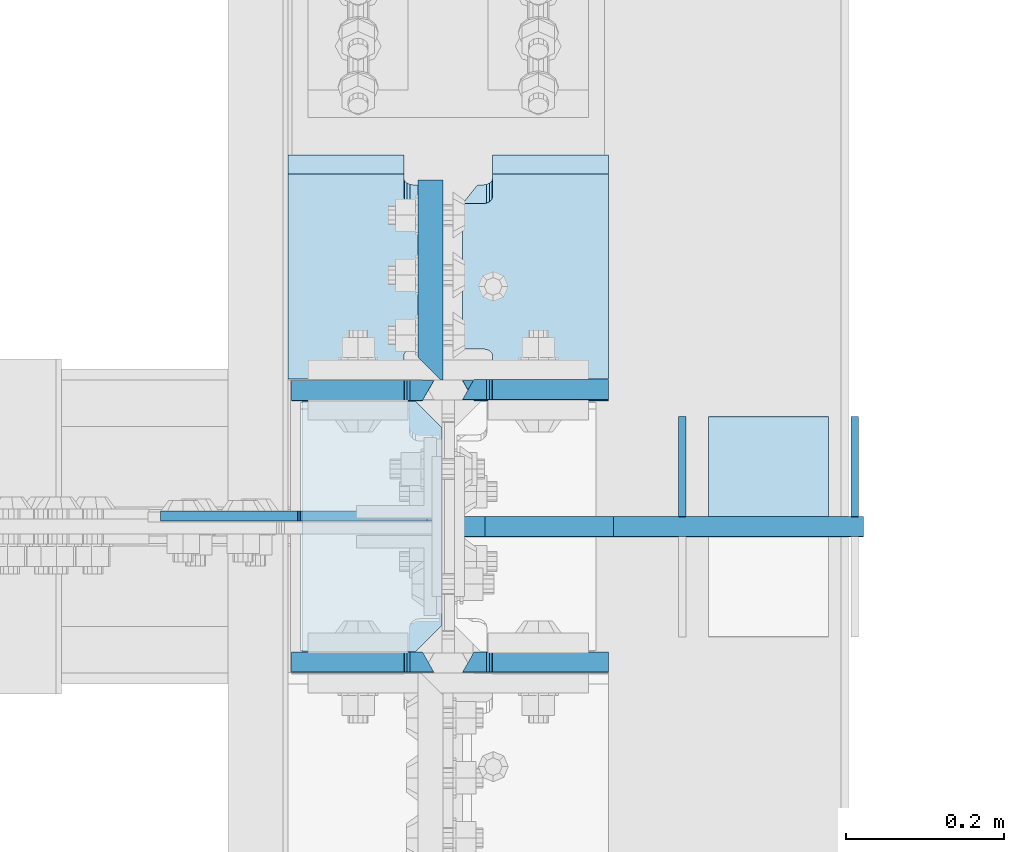
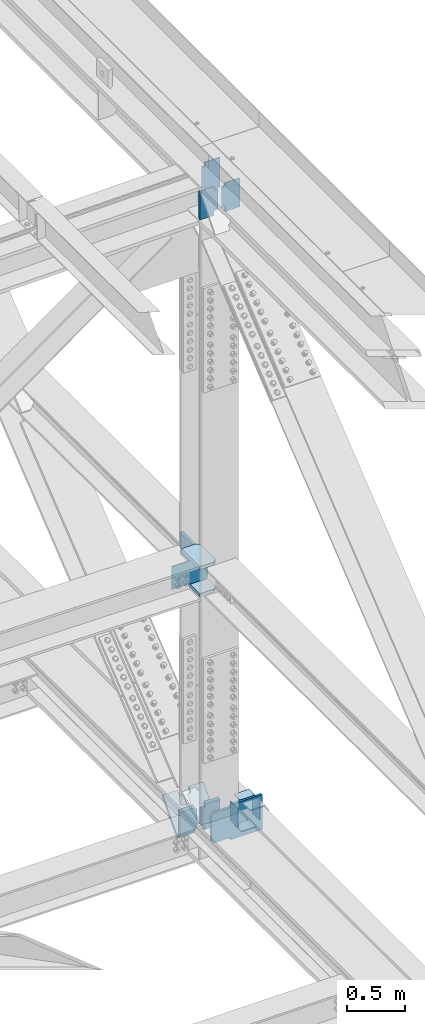
# One storey, part 3621 of 3843: 16 plates, 7 elements without a shape of their own.
"""IFC2X3 building model written with IfcOpenShell, lengths in millimetres."""

from ifc_helpers import new_model, si_unit, frame, origin_with_axes, place, context, subcontext, project, spatial, faceted_brep, material, type_object, element, aggregate, save


model = new_model("IFC2X3")

# Units and contexts
model_context = context("Model", 3, precision=1e-05, world=origin_with_axes())
body_context = subcontext(model_context, "Body", "Model", "MODEL_VIEW")
ifc_project = project(units=[si_unit("LENGTHUNIT", "METRE", prefix="MILLI"), si_unit("AREAUNIT", "SQUARE_METRE"), si_unit("VOLUMEUNIT", "CUBIC_METRE"), si_unit("MASSUNIT", "GRAM", prefix="KILO"), si_unit("TIMEUNIT", "SECOND"), si_unit("PLANEANGLEUNIT", "RADIAN"), si_unit("SOLIDANGLEUNIT", "STERADIAN"), si_unit("THERMODYNAMICTEMPERATUREUNIT", "DEGREE_CELSIUS"), si_unit("LUMINOUSINTENSITYUNIT", "LUMEN")], contexts=[model_context])

# Site, building, storey
site_placement = place(None, origin_with_axes())
site = spatial("IfcSite", under=ifc_project, at=site_placement, CompositionType="ELEMENT")
building_placement = place(site_placement, origin_with_axes())
building = spatial("IfcBuilding", under=site, at=building_placement, Name="Undefined", CompositionType="ELEMENT")
storey_placement = place(building_placement, origin_with_axes())
storey = spatial("IfcBuildingStorey", under=building, at=storey_placement, Name="Undefined", CompositionType="ELEMENT", Elevation=0.0)

# Assembly, plate
assembly_1_placement = place(storey_placement, origin_with_axes())
assembly_1 = element("IfcElementAssembly", 1, at=assembly_1_placement, inside=storey, Name="BEAM", AssemblyPlace="NOTDEFINED", PredefinedType="RIGID_FRAME")
ifc_material = material(Name="STEEL/A572-50")
plate_type_1 = type_object("IfcPlateType", PredefinedType="NOTDEFINED")
plate_1_placement = place(assembly_1_placement, frame((85852.0, 75800.2611777543, 39371.5363592028), z_axis=(0.0, 0.00349392500078829, 0.999993896225416), x_axis=(-1.0, 0.0, 0.0)))
plate_1 = element("IfcPlate", 2, at=plate_1_placement, type_object=plate_type_1, material=ifc_material, Name="PLATE", context=body_context, shape_type="Brep", body=[
    faceted_brep([(146.843749999985, -12.7000000009139, 314.307995056697), (146.843749999985, 12.6999999991967, 299.816503301714), (0.0, 12.6999999991967, 299.816503301721), (0.0, -12.7000000009139, 314.307995056697), (0.0, -12.700000000099, 19.4053954921328), (0.0, 12.6999999999243, 33.8968872505939), (146.843749999985, 12.6999999999243, 33.8968872505939), (146.843749999985, -12.700000000099, 19.4053954921328), (146.843749999985, 12.6999999998661, 56.9952036572431), (146.843749999985, -12.7000000002008, 56.9064567435853), (147.810479922569, 12.6999999998661, 61.855312840773), (147.810479922569, -12.7000000002154, 61.7665659271224), (150.563493823051, 12.699999999837, 65.9755144581213), (150.563493823051, -12.7000000002299, 65.8867675444562), (154.683670291211, 12.6999999998516, 68.728545162754), (154.683670291211, -12.7000000002445, 68.6397982490817), (159.543749809251, 12.699999999837, 69.6952809861614), (159.543749809251, -12.700000000259, 69.6065340725108), (170.452258243124, 12.699999999837, 69.6952809861614), (184.943749999991, -12.700000000259, 69.6065340725108), (184.943749999991, -12.6999999997643, 263.417469235843), (170.452258242993, 12.7000000003609, 263.506216142385), (159.543749809251, 12.6999999992186, 263.506216155103), (159.543749809251, -12.7000000008484, 263.417469232591), (154.683670291211, 12.6999999992113, 264.472951978518), (154.683670291211, -12.7000000008557, 264.384205056005), (150.563493823051, 12.699999999204, 267.225982683158), (150.563493823051, -12.7000000008629, 267.137235760645), (147.810479922569, 12.6999999991895, 271.346184300499), (147.810479922569, -12.7000000008702, 271.257437377986), (146.843749999985, 12.6999999991749, 276.206293484036), (146.843749999985, -12.7000000008848, 276.117546561523)], [[[0, 1, 2, 3]], [[4, 5, 6, 7]], [[7, 6, 8, 9]], [[9, 8, 10, 11]], [[11, 10, 12, 13]], [[13, 12, 14, 15]], [[15, 14, 16, 17]], [[17, 16, 18, 19]], [[20, 19, 18, 21]], [[22, 23, 20, 21]], [[23, 22, 24, 25]], [[25, 24, 26, 27]], [[27, 26, 28, 29]], [[29, 28, 30, 31]], [[4, 7, 9, 11, 13, 15, 17, 19, 20, 23, 25, 27, 29, 31, 0, 3]], [[5, 4, 3, 2]], [[30, 28, 26, 24, 22, 21, 18, 16, 14, 12, 10, 8, 6, 5, 2, 1]], [[31, 30, 1, 0]]]),
])

# Assembly, plates
assembly_2_placement = place(storey_placement, origin_with_axes())
assembly_2 = element("IfcElementAssembly", 3, at=assembly_2_placement, inside=storey, Name="BEAM", AssemblyPlace="NOTDEFINED", PredefinedType="RIGID_FRAME")
plate_2_placement = place(assembly_2_placement, frame((85852.0, 75455.6307364582, 46144.796667349), z_axis=(0.0, 0.00329764299921226, 0.999994562760543), x_axis=(-1.0, 0.0, 0.0)))
plate_2 = element("IfcPlate", 4, at=plate_2_placement, type_object=plate_type_1, material=ifc_material, Name="PLATE", context=body_context, shape_type="Brep", body=[
    faceted_brep([(146.84375, -12.7000000000553, 38.0114858507077), (146.84375, 12.7000000001281, 38.1002327741662), (147.810479922584, 12.7000000001281, 42.9603419576888), (147.810479922584, -12.7000000000553, 42.8715950342303), (150.563493823065, 12.7000000001281, 47.0805435750153), (150.563493823065, -12.7000000000553, 46.9917966515568), (154.683670291226, 12.7000000001281, 49.8335742796335), (154.683670291226, -12.7000000000407, 49.7448273561822), (159.543749809265, 12.7000000001426, 50.8003101030481), (159.543749809265, -12.7000000000407, 50.7115631795969), (184.943749999991, 12.7000000001426, 50.8003101030481), (170.452258242891, -12.7000000000407, 50.7115631795969), (184.943749999991, 12.7000000002081, 263.506216153903), (170.452258242891, -12.699999999837, 263.417469255888), (159.543749809251, 12.6999999992186, 263.506216155103), (159.543749809251, -12.7000000008484, 263.417469232591), (154.683670291211, 12.6999999992113, 264.472951978518), (154.683670291211, -12.7000000008557, 264.384205056005), (150.563493823051, 12.699999999204, 267.225982683158), (150.563493823051, -12.7000000008629, 267.137235760645), (147.810479922569, 12.6999999991895, 271.346184300499), (147.810479922569, -12.7000000008702, 271.257437377986), (146.843749999985, 12.6999999991749, 276.206293484036), (146.843749999985, -12.7000000008848, 276.117546561523), (146.843749999985, 12.700000001656, 303.95027208051), (146.843749999985, -12.6999999984982, 289.458780324741), (0.0, 12.700000001656, 303.95027208051), (0.0, -12.6999999984982, 289.458780324741), (0.0, 12.6999999999971, 0.0), (0.0, -12.7000000000771, 14.4914917543283), (146.843749999985, -12.7000000000771, 14.4914917543283), (146.843749999985, 12.7000000000262, 4.36557456851006e-11)], [[[0, 1, 2, 3]], [[3, 2, 4, 5]], [[5, 4, 6, 7]], [[7, 6, 8, 9]], [[9, 8, 10, 11]], [[12, 13, 11, 10]], [[14, 15, 13, 12]], [[15, 14, 16, 17]], [[17, 16, 18, 19]], [[19, 18, 20, 21]], [[21, 20, 22, 23]], [[24, 25, 23, 22]], [[26, 27, 25, 24]], [[27, 26, 28, 29]], [[0, 3, 5, 7, 9, 11, 13, 15, 17, 19, 21, 23, 25, 27, 29, 30]], [[1, 0, 30, 31]], [[26, 24, 22, 20, 18, 16, 14, 12, 10, 8, 6, 4, 2, 1, 31, 28]], [[30, 29, 28, 31]]]),
])
plate_3_placement = place(assembly_2_placement, frame((85852.0, 75801.7043463839, 46143.8045161096), z_axis=(0.0, 0.00329764299921226, 0.999994562760543), x_axis=(-1.0, 0.0, 0.0)))
plate_3 = element("IfcPlate", 5, at=plate_3_placement, type_object=plate_type_1, material=ifc_material, Name="PLATE", context=body_context, shape_type="Brep", body=[
    faceted_brep([(146.843749999985, 12.7000000017288, 314.312938163443), (0.0, 12.7000000017288, 314.312938163443), (0.0, -12.69999999844, 299.821446403119), (146.843749999985, -12.69999999844, 299.821446403119), (146.843749999985, -12.7000000000771, 14.4914917543283), (0.0, -12.7000000000771, 14.4914917543283), (0.0, 12.6999999999971, 0.0), (146.843749999985, 12.7000000000262, 4.36557456851006e-11), (146.843749999985, 12.6999999999098, 38.1890602041385), (146.843749999985, -12.7000000001572, 38.1003132816259), (147.810479922569, 12.6999999998952, 43.0491693876829), (147.810479922569, -12.7000000001644, 42.9604224651703), (150.563493823051, 12.6999999998734, 47.169371005024), (150.563493823051, -12.7000000001863, 47.0806240825113), (154.683670291211, 12.6999999998734, 49.9224017096567), (154.683670291211, -12.7000000001935, 49.833654787144), (159.543749809251, 12.6999999998661, 50.8891375330786), (159.543749809251, -12.7000000001935, 50.800390610566), (184.943749999991, 12.7000000001572, 50.8891375333405), (170.452258242833, -12.7000000000262, 50.800390609882), (184.943749999991, 12.7000000002081, 263.506216153903), (170.452258242891, -12.699999999837, 263.417469255888), (159.543749809251, 12.6999999992186, 263.506216155103), (159.543749809251, -12.7000000008484, 263.417469232591), (154.683670291211, 12.6999999992113, 264.472951978518), (154.683670291211, -12.7000000008557, 264.384205056005), (150.563493823051, 12.699999999204, 267.225982683158), (150.563493823051, -12.7000000008629, 267.137235760645), (147.810479922569, 12.6999999991895, 271.346184300499), (147.810479922569, -12.7000000008702, 271.257437377986), (146.843749999985, 12.6999999991749, 276.206293484036), (146.843749999985, -12.7000000008848, 276.117546561523)], [[[0, 1, 2, 3]], [[4, 5, 6, 7]], [[8, 9, 4, 7]], [[9, 8, 10, 11]], [[11, 10, 12, 13]], [[13, 12, 14, 15]], [[15, 14, 16, 17]], [[17, 16, 18, 19]], [[20, 21, 19, 18]], [[22, 23, 21, 20]], [[23, 22, 24, 25]], [[25, 24, 26, 27]], [[27, 26, 28, 29]], [[29, 28, 30, 31]], [[31, 30, 0, 3]], [[5, 4, 9, 11, 13, 15, 17, 19, 21, 23, 25, 27, 29, 31, 3, 2]], [[6, 5, 2, 1]], [[30, 28, 26, 24, 22, 20, 18, 16, 14, 12, 10, 8, 7, 6, 1, 0]]]),
])

# Assembly, plate
assembly_3_placement = place(storey_placement, origin_with_axes())
assembly_3 = element("IfcElementAssembly", 6, at=assembly_3_placement, inside=storey, Name="COLUMN", AssemblyPlace="NOTDEFINED", PredefinedType="RIGID_FRAME")
plate_type_2 = type_object("IfcPlateType", PredefinedType="NOTDEFINED")
plate_4_placement = place(assembly_3_placement, frame((85640.8625, 75641.9937500954, 42192.071348413), z_axis=(-0.707106781186548, 0.0, 0.707106781186548), x_axis=(-0.707106781186548, 0.0, -0.707106781186548)))
plate_4 = element("IfcPlate", 7, at=plate_4_placement, type_object=plate_type_2, material=ifc_material, Name="PLATE", context=body_context, shape_type="Brep", body=[
    faceted_brep([(0.0, -6.3499999046162, 0.0), (-152.665587827403, -6.34999999999854, 152.665587827403), (-152.665587827403, 6.34999999999854, 152.665587827403), (7.27595761418343e-12, 6.3499999046162, 0.0), (-152.665587827112, -6.34999999999854, 179.606356190761), (-152.665587827112, 6.34999999999854, 179.606356190761), (-39.2898544208874, -6.34999999999854, 292.982089845096), (-39.2898544208874, 6.34999999999854, 292.982089845096), (-37.2519695532828, -6.34999999999854, 291.620418710037), (-37.2519695532828, 6.34999999999854, 291.620418710037), (-34.8481204507552, -6.34999999999854, 291.142263394238), (-34.8481204507552, 6.34999999999854, 291.142263394238), (-32.4442713482422, -6.34999999999854, 291.620418710056), (-32.4442713482422, 6.34999999999854, 291.620418710056), (-30.406386480623, -6.34999999999854, 292.98208984514), (-30.406386480623, 6.34999999999854, 292.98208984514), (90.8754652461794, -6.34999999999854, 414.263941571935), (90.8754652461794, 6.34999999999854, 414.263941571935), (261.500331545671, -6.34999999999854, 243.639075272451), (261.500331545671, 6.34999999999854, 243.639075272451), (140.316501924579, -6.34999999999854, 122.455245651345), (140.316501924579, 6.34999999999854, 122.455245651345), (138.924780842135, -6.34999999999854, 120.372387859356), (138.924780842135, 6.34999999999854, 120.372387859356), (138.436073388089, -6.34999999999854, 117.915489575513), (138.436073388089, 6.34999999999854, 117.915489575513), (138.924780842121, -6.34999999999854, 115.458591291659), (138.924780842121, 6.34999999999854, 115.458591291659), (140.316501893642, -6.34999999999854, 113.375733530571), (140.316501893642, 6.34999999999854, 113.375733530571), (26.9407683632217, -6.34999999999854, 1.30967237055302e-10), (26.9407683632217, 6.34999999999854, 1.30967237055302e-10)], [[[0, 1, 2, 3]], [[1, 4, 5, 2]], [[4, 6, 7, 5]], [[6, 8, 9, 7]], [[8, 10, 11, 9]], [[10, 12, 13, 11]], [[12, 14, 15, 13]], [[14, 16, 17, 15]], [[16, 18, 19, 17]], [[18, 20, 21, 19]], [[20, 22, 23, 21]], [[22, 24, 25, 23]], [[24, 26, 27, 25]], [[26, 28, 29, 27]], [[28, 30, 31, 29]], [[30, 0, 3, 31]], [[5, 7, 9, 11, 13, 15, 17, 19, 21, 23, 25, 27, 29, 31, 3, 2]], [[30, 28, 26, 24, 22, 20, 18, 16, 14, 12, 10, 8, 6, 4, 1, 0]]]),
])

# Plate
plate_type_3 = type_object("IfcPlateType", PredefinedType="NOTDEFINED")
plate_5_placement = place(assembly_1_placement, frame((85630.54375, 75800.2611777543, 39371.5363592028), z_axis=(0.0, 0.00349392500078829, 0.999993896225416), x_axis=(-1.0, 0.0, 0.0)))
plate_5 = element("IfcPlate", 8, at=plate_5_placement, type_object=plate_type_3, material=ifc_material, Name="PLATE", context=body_context, shape_type="Brep", body=[
    faceted_brep([(180.974999999991, -12.7000000009139, 314.307995056697), (180.974999999991, 12.6999999991967, 299.816503301721), (38.1000000000058, 12.6999999991967, 299.816503301714), (38.1000000000058, -12.6996899253718, 314.217780397244), (38.1000000000058, -12.7000000008848, 276.117546561538), (38.1000000000058, 12.6999999991749, 276.206293484051), (37.1332700774219, 12.6999999991895, 271.346184300513), (37.1332700774219, -12.7000000008702, 271.257437378001), (34.3802561769407, 12.699999999204, 267.225982683172), (34.3802561769407, -12.7000000008629, 267.13723576066), (30.2600797087798, 12.6999999992113, 264.472951978532), (30.2600797087798, -12.7000000008557, 264.38420505602), (25.4000001907407, 12.6999999992186, 263.506216155118), (25.4000001907407, -12.7000000008484, 263.417469232605), (14.4914917569986, 12.7000000003463, 263.506216154878), (0.0, -12.6999999997643, 263.417469223023), (14.4914917568676, 12.699999999837, 69.695280986205), (0.0, -12.700000000259, 69.6065340725545), (25.4000001907407, 12.699999999837, 69.695280986205), (25.4000001907407, -12.700000000259, 69.6065340725545), (30.2600797087798, 12.6999999998516, 68.7285451627977), (30.2600797087798, -12.7000000002445, 68.6397982491253), (34.3802561769407, 12.699999999837, 65.975514458165), (34.3802561769407, -12.7000000002299, 65.8867675445072), (37.1332700774219, 12.6999999998661, 61.8553128408166), (37.1332700774219, -12.7000000002154, 61.7665659271661), (38.1000000000058, 12.6999999998661, 56.9952036572868), (38.1000000000058, -12.7000000002008, 56.906456743629), (38.1000000000058, 12.6999999999243, 33.8968872505793), (38.1000000000058, -12.700000000099, 19.4053954921183), (180.974999999991, 12.6999999999243, 33.8968872505793), (180.974999999991, -12.700000000099, 19.4053954921183)], [[[0, 1, 2, 3]], [[4, 5, 6, 7]], [[7, 6, 8, 9]], [[9, 8, 10, 11]], [[11, 10, 12, 13]], [[13, 12, 14, 15]], [[14, 16, 17, 15]], [[18, 19, 17, 16]], [[19, 18, 20, 21]], [[21, 20, 22, 23]], [[23, 22, 24, 25]], [[25, 24, 26, 27]], [[27, 26, 28, 29]], [[30, 31, 29, 28]], [[4, 7, 9, 11, 13, 15, 17, 19, 21, 23, 25, 27, 29, 31, 0, 3]], [[5, 4, 3, 2]], [[30, 28, 26, 24, 22, 20, 18, 16, 14, 12, 10, 8, 6, 5, 2, 1]], [[31, 30, 1, 0]]]),
])

plate_6_placement = place(assembly_2_placement, frame((85630.54375, 75455.6307364582, 46144.796667349), z_axis=(0.0, 0.00329764299921226, 0.999994562760543), x_axis=(-1.0, 0.0, 0.0)))
plate_6 = element("IfcPlate", 9, at=plate_6_placement, type_object=plate_type_3, material=ifc_material, Name="PLATE", context=body_context, shape_type="Brep", body=[
    faceted_brep([(180.974999999991, -12.7000000000844, 14.4914917571878), (38.1000000000058, -12.7000000000771, 14.4914917543283), (38.1000000000058, 12.7000000000262, 4.36557456851006e-11), (180.974999999991, 12.7000000000844, -7.27595761418343e-12), (37.1332700774074, -12.7000000000553, 42.8715950345577), (37.1332700774074, 12.7000000001281, 42.9603419580089), (38.0999999999913, 12.7000000001281, 38.1002327744864), (38.0999999999913, -12.7000000000553, 38.0114858510351), (34.3802561769262, -12.7000000000553, 46.9917966518769), (34.3802561769262, 12.7000000001281, 47.0805435753355), (30.2600797087653, -12.7000000000407, 49.7448273565024), (30.2600797087653, 12.7000000001281, 49.8335742799536), (25.4000001907261, -12.7000000000407, 50.711563179917), (25.4000001907261, 12.7000000001426, 50.8003101033755), (14.4914917571004, -12.7000000000407, 50.711563179917), (0.0, 12.7000000001426, 50.8003101033755), (14.4914917568531, -12.7000000008484, 263.417469232605), (0.0, 12.6999999992186, 263.506216155118), (25.4000001907407, -12.7000000008484, 263.417469232605), (25.4000001907407, 12.6999999992186, 263.506216155118), (30.2600797087798, -12.7000000008557, 264.38420505602), (30.2600797087798, 12.6999999992113, 264.472951978532), (34.3802561769407, -12.7000000008629, 267.13723576066), (34.3802561769407, 12.699999999204, 267.225982683172), (37.1332700774219, -12.7000000008702, 271.257437378001), (37.1332700774219, 12.6999999991895, 271.346184300513), (38.1000000000058, -12.7000000008848, 276.117546561538), (38.1000000000058, 12.6999999991749, 276.206293484051), (38.1000000000058, 12.700000001656, 303.95027208051), (38.1000000000058, -12.6999999984982, 289.458780324741), (180.974999999991, -12.6999999984982, 289.458780324741), (180.974999999991, 12.700000001656, 303.95027208051)], [[[0, 1, 2, 3]], [[4, 5, 6, 7]], [[8, 9, 5, 4]], [[10, 11, 9, 8]], [[12, 13, 11, 10]], [[13, 12, 14, 15]], [[16, 17, 15, 14]], [[18, 19, 17, 16]], [[20, 21, 19, 18]], [[22, 23, 21, 20]], [[24, 25, 23, 22]], [[26, 27, 25, 24]], [[28, 27, 26, 29]], [[30, 31, 28, 29]], [[31, 30, 0, 3]], [[6, 5, 9, 11, 13, 15, 17, 19, 21, 23, 25, 27, 28, 31, 3, 2]], [[7, 6, 2, 1]], [[30, 29, 26, 24, 22, 20, 18, 16, 14, 12, 10, 8, 4, 7, 1, 0]]]),
])

aggregate(assembly_2, [plate_2, plate_6, plate_3])

plate_type_4 = type_object("IfcPlateType", PredefinedType="NOTDEFINED")
plate_7_placement = place(assembly_1_placement, frame((85445.6, 76088.1111793516, 39674.2855849514), z_axis=(0.0, -0.662914452626385, -0.748695150578031), x_axis=(1.0, 0.0, 0.0)))
plate_7 = element("IfcPlate", 10, at=plate_7_placement, type_object=plate_type_4, material=ifc_material, Name="PLATE", context=body_context, shape_type="Brep", body=[
    faceted_brep([(165.893749999988, -15.8750000001892, 57.1497682512127), (184.943749999991, 15.8749999999127, 57.1499051690625), (184.943743896481, 15.8749999992579, 335.346266448745), (165.893743896479, -15.8750000008476, 335.346018382654), (154.683905942948, -15.8750000001892, 56.1831013699993), (154.683905942948, 15.8749999999127, 56.1833494360908), (159.543996806155, 15.8749999999127, 57.1500533652579), (159.543996806155, -15.8750000001892, 57.149805299181), (150.563710384493, -15.8750000001783, 53.430105139385), (150.563710384493, 15.8749999999127, 53.4303532054619), (147.810674088149, -15.8750000001746, 49.3099363519141), (147.810674088149, 15.8749999999345, 49.3101844180055), (146.843922898159, -15.8750000001637, 44.4498548893025), (146.843922898159, 15.8749999999418, 44.450102955394), (146.843749999985, -15.8750000000582, -1.30967237055302e-10), (146.843749999985, 15.8750000000437, 1.01863406598568e-10), (0.0, -15.875, 0.0), (0.0, 15.875, 0.0), (0.0, -15.875000000975, 392.496138987422), (0.0, 15.8749999991305, 392.496138987655), (146.843966194254, -15.875000000975, 392.496138987422), (146.843966194254, 15.8749999991305, 392.496138987655), (146.843793296168, -15.8750000008731, 348.046067591757), (146.843793296168, 15.8749999992287, 348.046315657848), (147.810509040442, -15.8750000008586, 343.185972903491), (147.810509040442, 15.8749999992469, 343.186220969583), (150.563519653791, -15.8750000008476, 339.065779671204), (150.563519653791, 15.8749999992542, 339.066027737295), (154.683702177499, -15.875000000844, 336.312753031365), (154.683702177499, 15.8749999992651, 336.313001097456), (159.543793105346, -15.8750000008476, 335.346018382654), (159.543793105346, 15.8749999992579, 335.346266448745)], [[[0, 1, 2, 3]], [[4, 5, 6, 7]], [[8, 9, 5, 4]], [[10, 11, 9, 8]], [[12, 13, 11, 10]], [[14, 15, 13, 12]], [[16, 17, 15, 14]], [[16, 18, 19, 17]], [[19, 18, 20, 21]], [[20, 22, 23, 21]], [[24, 25, 23, 22]], [[26, 27, 25, 24]], [[28, 29, 27, 26]], [[30, 31, 29, 28]], [[31, 30, 3, 2]], [[6, 5, 9, 11, 13, 15, 17, 19, 21, 23, 25, 27, 29, 31, 2, 1]], [[7, 6, 1, 0]], [[30, 28, 26, 24, 22, 20, 18, 16, 14, 12, 10, 8, 4, 7, 0, 3]]]),
])

plate_8_placement = place(assembly_1_placement, frame((85663.88125, 76088.1111793516, 39674.2855849514), z_axis=(0.0, -0.662914452626385, -0.748695150578031), x_axis=(1.0, 0.0, 0.0)))
plate_8 = element("IfcPlate", 11, at=plate_8_placement, type_object=plate_type_4, material=ifc_material, Name="PLATE", context=body_context, shape_type="Brep", body=[
    faceted_brep([(3.17499999998836, 15.8749999999127, 57.1501274642651), (22.2250000000931, -15.8750000005602, 57.1497682499321), (22.224777702213, -15.8750000008295, 335.346018381068), (3.17477770221012, 15.8749999992724, 335.346266447174), (28.5748519917834, -15.8750000005602, 57.1497312013817), (28.5748519917834, 15.87499999992, 57.1499792674585), (33.4349087547453, 15.87499999992, 56.183228077658), (33.4349087547453, -15.8750000005748, 56.1829800115665), (37.5550600770075, 15.8749999999309, 53.4302092465805), (37.5550600770075, -15.8750000005712, 53.4299611805036), (40.308054868714, 15.8749999999382, 49.3100418616523), (40.308054868714, -15.8750000005821, 49.3097937955754), (41.2747777022159, 15.8749999999491, 44.4499794580915), (41.2747777022159, -15.8750000005894, 44.4497313920001), (41.2747777022159, 15.8750000000582, 1.01863406598568e-10), (41.2747777022159, -15.8750000000291, 2.91038304567337e-11), (188.118743896484, 15.8750000000582, 1.01863406598568e-10), (188.118743896484, -15.8750000000509, -1.16415321826935e-10), (188.118743896484, -15.875000000975, 392.496138987379), (188.118743896484, 15.8749999991378, 392.496138987612), (41.2747777022159, 15.8749999991378, 392.496138987612), (41.2747777022159, -15.8749999982901, 392.495796089381), (41.2747777022159, 15.8749999992469, 348.046266256773), (41.2747777022159, -15.8750000008586, 348.046018190682), (40.308047779632, 15.8749999992579, 343.186186738589), (40.308047779632, -15.8750000008513, 343.185938672512), (37.5550338791509, 15.8749999992579, 339.066010270326), (37.5550338791509, -15.875000000844, 339.065762204249), (33.4348574109899, 15.8749999992651, 336.312996369772), (33.4348574109899, -15.8750000008367, 336.312748303695), (28.5747778929508, 15.8749999992724, 335.346266447174), (28.5747778929508, -15.8750000008295, 335.346018381068)], [[[0, 1, 2, 3]], [[4, 5, 6, 7]], [[7, 6, 8, 9]], [[9, 8, 10, 11]], [[11, 10, 12, 13]], [[13, 12, 14, 15]], [[16, 17, 15, 14]], [[18, 17, 16, 19]], [[18, 19, 20, 21]], [[21, 20, 22, 23]], [[23, 22, 24, 25]], [[25, 24, 26, 27]], [[27, 26, 28, 29]], [[29, 28, 30, 31]], [[4, 7, 9, 11, 13, 15, 17, 18, 21, 23, 25, 27, 29, 31, 2, 1]], [[5, 4, 1, 0]], [[30, 28, 26, 24, 22, 20, 19, 16, 14, 12, 10, 8, 6, 5, 0, 3]], [[31, 30, 3, 2]]]),
])

plate_type_5 = type_object("IfcPlateType", PredefinedType="NOTDEFINED")
plate_9_placement = place(assembly_3_placement, frame((85463.0624999861, 75787.2499579908, 42156.8434231544), z_axis=(0.0, -1.0, 0.0), x_axis=(1.0, 0.0, 0.0)))
plate_9 = element("IfcPlate", 12, at=plate_9_placement, type_object=plate_type_5, material=ifc_material, Name="PLATE", context=body_context, shape_type="Brep", body=[
    faceted_brep([(0.0, -15.875, 0.0), (0.0, -15.875, 317.5), (0.0, 15.875, 317.5), (0.0, 15.875, 0.0), (144.462498511086, -15.874999999156, 317.499999999665), (144.462498511086, 15.875000000844, 317.499999999578), (177.800000033079, -15.8749999992506, 284.162498473786), (177.800000033079, 15.8750000007494, 284.162498473699), (177.800000003888, -15.8749999999054, 33.3375015259226), (177.800000003888, 15.8750000000946, 33.3375015258353), (144.462498474124, -15.875, 0.0), (144.462498474124, 15.875, 0.0)], [[[0, 1, 2, 3]], [[1, 4, 5, 2]], [[4, 6, 7, 5]], [[6, 8, 9, 7]], [[8, 10, 11, 9]], [[10, 0, 3, 11]], [[5, 7, 9, 11, 3, 2]], [[10, 8, 6, 4, 1, 0]]]),
])

plate_10_placement = place(assembly_3_placement, frame((85463.0624999861, 75787.2499479903, 42442.5938715778), z_axis=(0.0, -1.0, 0.0), x_axis=(1.0, 0.0, 0.0)))
plate_10 = element("IfcPlate", 13, at=plate_10_placement, type_object=plate_type_5, material=ifc_material, Name="PLATE", context=body_context, shape_type="Brep", body=[
    faceted_brep([(0.0, -15.875, 0.0), (0.0, -15.875, 317.5), (0.0, 15.875, 317.5), (0.0, 15.875, 0.0), (144.462498511086, -15.874999999156, 317.499999999665), (144.462498511086, 15.875000000844, 317.499999999578), (177.800000033079, -15.8749999992506, 284.162498473786), (177.800000033079, 15.8750000007494, 284.162498473699), (177.800000003888, -15.8749999999054, 33.3375015259226), (177.800000003888, 15.8750000000946, 33.3375015258353), (144.462498474124, -15.875, 0.0), (144.462498474124, 15.875, 0.0)], [[[0, 1, 2, 3]], [[1, 4, 5, 2]], [[4, 6, 7, 5]], [[6, 8, 9, 7]], [[8, 10, 11, 9]], [[10, 0, 3, 11]], [[5, 7, 9, 11, 3, 2]], [[10, 8, 6, 4, 1, 0]]]),
])

plate_type_6 = type_object("IfcPlateType", PredefinedType="NOTDEFINED")
plate_11_placement = place(assembly_1_placement, frame((86175.8500000045, 75627.9277251634, 39345.0399264112), z_axis=(0.0, 0.00146611400037363, 0.999998925254291), x_axis=(-1.0, 0.0, 0.0)))
plate_11 = element("IfcPlate", 14, at=plate_11_placement, type_object=plate_type_6, material=ifc_material, Name="STIFFENER", context=body_context, shape_type="Brep", body=[
    faceted_brep([(0.0, -12.6999999999971, 0.0), (1.43627403303981e-08, -12.7000000003172, 368.282421855467), (1.43627403303981e-08, 12.6999999996769, 368.282421855489), (0.0, 12.6999999999971, 0.0), (317.500000026223, -12.7000000003172, 368.282421839234), (317.500000026223, 12.6999999996769, 368.282421839256), (317.500000024767, -12.7000000002881, 342.88242181766), (317.500000024767, 12.6999999996915, 342.882421817681), (480.218749970372, -12.7000000002881, 342.882421787188), (480.218749970372, 12.6999999996915, 342.88242178721), (511.968749969019, -12.700000000259, 311.132421781258), (511.968749969019, 12.6999999997206, 311.132421781287), (511.968749958221, -12.7000000000553, 57.1500000187953), (511.968749958221, 12.6999999999389, 57.1500000188171), (480.218749956868, -12.7000000000116, 25.4000000166852), (480.218749956868, 12.6999999999825, 25.4000000167216), (317.500000000146, -12.7000000000116, 25.4000000058295), (317.500000000146, 12.699999999968, 25.4000000058659), (317.50000000211, -12.6999999999971, -8.14907252788544e-10), (317.50000000211, 12.6999999999971, -7.93079379945993e-10)], [[[0, 1, 2, 3]], [[1, 4, 5, 2]], [[4, 6, 7, 5]], [[6, 8, 9, 7]], [[8, 10, 11, 9]], [[10, 12, 13, 11]], [[12, 14, 15, 13]], [[14, 16, 17, 15]], [[16, 18, 19, 17]], [[18, 0, 3, 19]], [[5, 7, 9, 11, 13, 15, 17, 19, 3, 2]], [[18, 16, 14, 12, 10, 8, 6, 4, 1, 0]]]),
])

aggregate(assembly_1, [plate_7, plate_8, plate_1, plate_5, plate_11])

plate_type_7 = type_object("IfcPlateType", PredefinedType="NOTDEFINED")
plate_12_placement = place(assembly_3_placement, frame((85626.575, 75814.2374490391, 42412.8634559154), z_axis=(0.0, 1.0, 0.0), x_axis=(0.0, 0.0, -1.0)))
plate_12 = element("IfcPlate", 15, at=plate_12_placement, type_object=plate_type_7, material=ifc_material, Name="PLATE", context=body_context, shape_type="Brep", body=[
    faceted_brep([(228.600000000064, 15.875, 28.5750007623283), (228.599999999991, -12.7000007629103, -5.82076609134674e-10), (0.0, -12.6999999999971, 0.0), (6.54836185276508e-11, 15.875, 28.5750007629249), (0.0, -15.875, 0.0), (6.69388100504875e-10, -15.875, 254.0), (6.69388100504875e-10, 15.875, 254.0), (228.600000000668, -15.875, 253.999999999403), (228.600000000668, 15.875, 253.999999999403), (228.599999999991, -15.875, -5.82076609134674e-10)], [[[0, 1, 2, 3]], [[4, 5, 6, 3, 2]], [[5, 7, 8, 6]], [[8, 7, 9, 1, 0]], [[9, 4, 2, 1]], [[6, 8, 0, 3]], [[9, 7, 5, 4]]]),
])

aggregate(assembly_3, [plate_12, plate_9, plate_10, plate_4])

# Assembly, plate
assembly_4_placement = place(storey_placement, origin_with_axes())
assembly_4 = element("IfcElementAssembly", 16, at=assembly_4_placement, inside=storey, Name="PLATE", AssemblyPlace="NOTDEFINED", PredefinedType="RIGID_FRAME")
plate_type_8 = type_object("IfcPlateType", PredefinedType="NOTDEFINED")
plate_13_placement = place(assembly_4_placement, frame((85945.6625, 75640.9745712487, 39632.404845315), z_axis=(0.0, 0.999999395455131, -0.00109958600053505), x_axis=(0.0, -0.00109957000053272, -0.999999395472724)))
plate_13 = element("IfcPlate", 17, at=plate_13_placement, type_object=plate_type_8, material=ifc_material, Name="PLATE", context=body_context, shape_type="Brep", body=[
    faceted_brep([(0.0, -4.76249999999709, 0.0), (0.0465491305512842, -4.76249999999709, 126.999991468285), (0.0465491305512842, 4.76249999999709, 126.999991468285), (0.0, 4.76249999999709, 0.0), (203.246508181677, -4.76249999999709, 126.999991467135), (203.246508181677, 4.76249999999709, 126.999991467135), (203.199999999997, -4.76249999999709, 0.0), (203.199999999997, 4.76249999999709, 0.0)], [[[0, 1, 2, 3]], [[1, 4, 5, 2]], [[4, 6, 7, 5]], [[6, 0, 3, 7]], [[5, 7, 3, 2]], [[6, 4, 1, 0]]]),
])
aggregate(assembly_4, [plate_13])

assembly_5_placement = place(storey_placement, origin_with_axes())
assembly_5 = element("IfcElementAssembly", 18, at=assembly_5_placement, inside=storey, Name="PLATE", AssemblyPlace="NOTDEFINED", PredefinedType="RIGID_FRAME")
plate_14_placement = place(assembly_5_placement, frame((86164.7375000001, 75640.9745712485, 39632.404845315), z_axis=(0.0, 0.999999395455131, -0.00109958600053505), x_axis=(0.0, -0.00109957000053272, -0.999999395472724)))
plate_14 = element("IfcPlate", 19, at=plate_14_placement, type_object=plate_type_8, material=ifc_material, Name="PLATE", context=body_context, shape_type="Brep", body=[
    faceted_brep([(0.0, -4.76249999999709, 0.0), (0.0465491305512842, -4.76249999999709, 126.999991468285), (0.0465491305512842, 4.76249999999709, 126.999991468285), (0.0, 4.76249999999709, 0.0), (203.246508181677, -4.76249999999709, 126.999991467135), (203.246508181677, 4.76249999999709, 126.999991467135), (203.199999999997, -4.76249999999709, 0.0), (203.199999999997, 4.76249999999709, 0.0)], [[[0, 1, 2, 3]], [[1, 4, 5, 2]], [[4, 6, 7, 5]], [[6, 0, 3, 7]], [[5, 7, 3, 2]], [[6, 4, 1, 0]]]),
])
aggregate(assembly_5, [plate_14])

assembly_6_placement = place(storey_placement, origin_with_axes())
assembly_6 = element("IfcElementAssembly", 20, at=assembly_6_placement, inside=storey, Name="PLATE", AssemblyPlace="NOTDEFINED", PredefinedType="RIGID_FRAME")
plate_15_placement = place(assembly_6_placement, frame((86131.4000000045, 75640.6673710888, 39372.0547467895), z_axis=(0.0, 0.999998925254291, -0.00146611400037364), x_axis=(-1.0, 0.0, 0.0)))
plate_15 = element("IfcPlate", 21, at=plate_15_placement, type_object=plate_type_8, material=ifc_material, Name="PLATE", context=body_context, shape_type="Brep", body=[
    faceted_brep([(0.0, -4.76249999999709, 0.0), (-5.82076609134674e-11, -4.76249999972788, 126.999999995154), (-5.82076609134674e-11, 4.76250000024447, 126.999999995183), (0.0, 4.76249999999709, 0.0), (152.399999999951, -4.76249999972788, 126.999999995154), (152.399999999951, 4.76250000024447, 126.999999995183), (152.399993896484, -4.76249999999709, 0.0), (152.399993896484, 4.76249999999709, 0.0)], [[[0, 1, 2, 3]], [[1, 4, 5, 2]], [[4, 6, 7, 5]], [[6, 0, 3, 7]], [[5, 7, 3, 2]], [[6, 4, 1, 0]]]),
])
aggregate(assembly_6, [plate_15])

assembly_7_placement = place(storey_placement, origin_with_axes())
assembly_7 = element("IfcElementAssembly", 22, at=assembly_7_placement, inside=storey, Name="PLATE", AssemblyPlace="NOTDEFINED", PredefinedType="RIGID_FRAME")
plate_16_placement = place(assembly_7_placement, frame((86131.3999975899, 75641.1328585906, 39689.5547292674), z_axis=(0.0, 0.999998925254291, -0.00146611400037364), x_axis=(-1.0, 0.0, 0.0)))
plate_16 = element("IfcPlate", 23, at=plate_16_placement, type_object=plate_type_8, material=ifc_material, Name="PLATE", context=body_context, shape_type="Brep", body=[
    faceted_brep([(0.0, -4.76249999999709, 0.0), (-5.82076609134674e-11, -4.76249999972788, 126.999999995154), (-5.82076609134674e-11, 4.76250000024447, 126.999999995183), (0.0, 4.76249999999709, 0.0), (152.399999999951, -4.76249999972788, 126.999999995154), (152.399999999951, 4.76250000024447, 126.999999995183), (152.399993896484, -4.76249999999709, 0.0), (152.399993896484, 4.76249999999709, 0.0)], [[[0, 1, 2, 3]], [[1, 4, 5, 2]], [[4, 6, 7, 5]], [[6, 0, 3, 7]], [[5, 7, 3, 2]], [[6, 4, 1, 0]]]),
])
aggregate(assembly_7, [plate_16])

save(model, "model.ifc")
